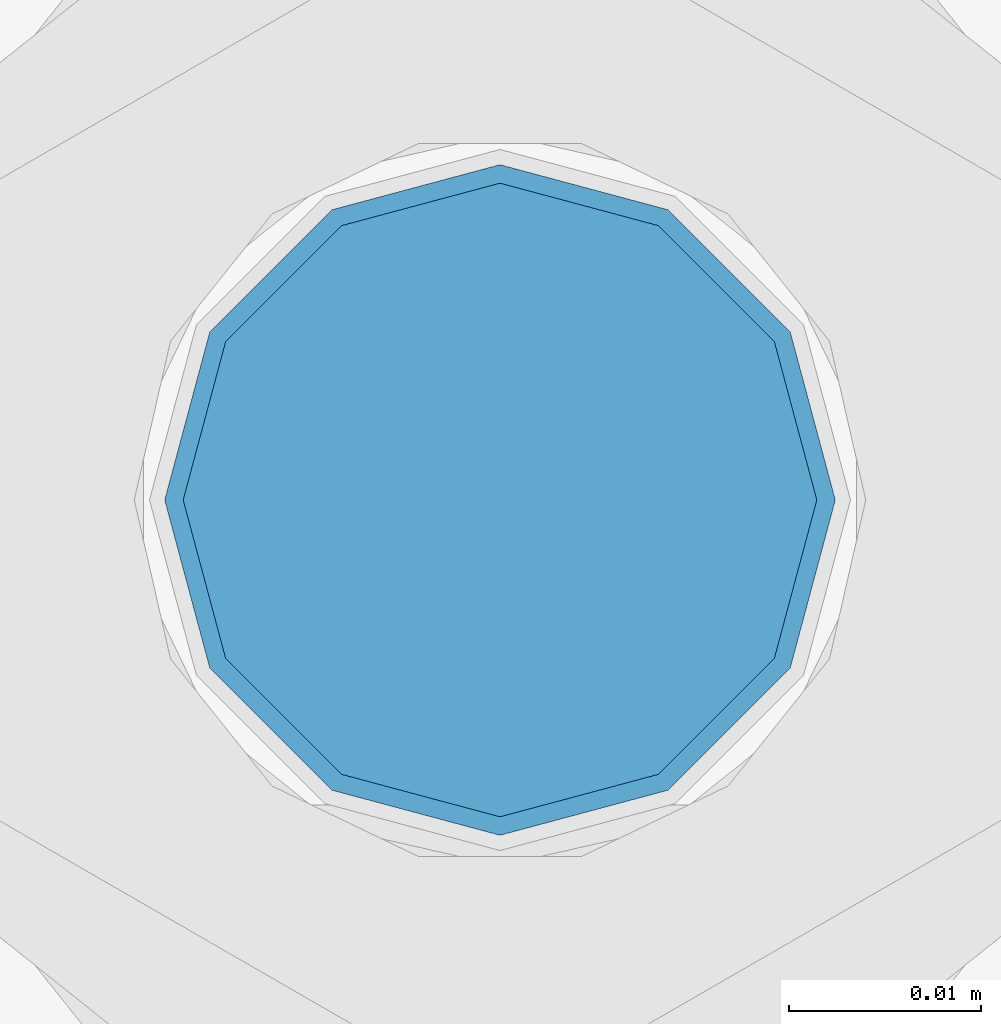
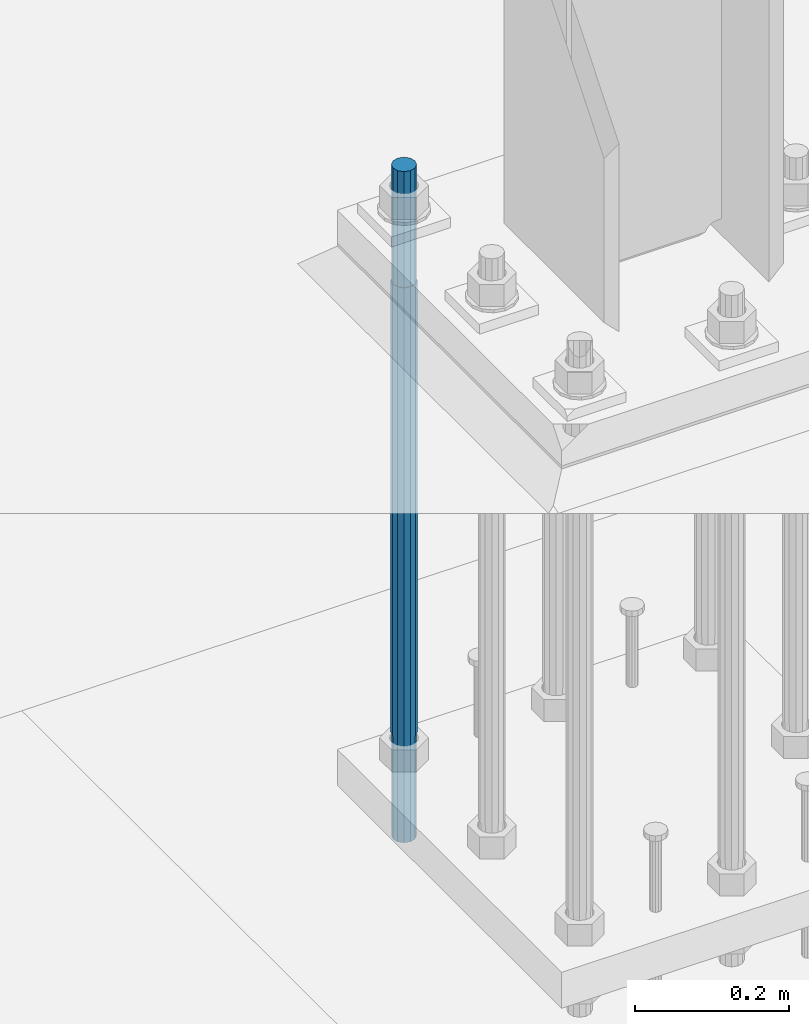
# One storey, part 567 of 1876: 1 column, 1 element without a shape of its own.
"""IFC2X3 building model written with IfcOpenShell, lengths in millimetres."""

import ifcopenshell
import ifcopenshell.guid

model = None  # the IFC model being written
_history = None  # IfcOwnerHistory: only IFC2X3 demands one
_inside = {}  # id of a spatial element -> (the spatial element, [elements in it])
_under = {}  # id of a project, library or spatial element -> (it, [spatial elements below it])
_declared = {}  # id of a project -> (the project, [libraries it declares])
_typed = {}  # id of a type object -> (the type object, [elements of that type])
_made_of = {}  # id of a material, layer set ... -> (it, [elements and type objects made of it])


def new_model(schema):
    """Start an empty IFC model of exactly this schema.

    Asked for "IFC4X3", IfcOpenShell would pick the latest addendum, in which some entities
    have other attributes; the version numbers below select the first issue.
    IFC2X3 requires an IfcOwnerHistory on every rooted entity: one is made here for all.
    """
    global model, _history
    if schema == "IFC4X3":
        model = ifcopenshell.file(schema_version=(4, 3, 0, 0))
    else:
        model = ifcopenshell.file(schema=schema)
    _inside.clear()
    _under.clear()
    _declared.clear()
    _typed.clear()
    _made_of.clear()
    _history = None
    if model.schema == "IFC2X3":
        org = make("IfcOrganization", Name="unknown")
        user = make(
            "IfcPersonAndOrganization",
            ThePerson=make("IfcPerson", FamilyName="unknown"),
            TheOrganization=org,
        )
        app = make(
            "IfcApplication",
            ApplicationDeveloper=org,
            Version="unknown",
            ApplicationFullName="unknown",
            ApplicationIdentifier="unknown",
        )
        _history = make(
            "IfcOwnerHistory",
            OwningUser=user,
            OwningApplication=app,
            ChangeAction="ADDED",
            CreationDate=0,
        )
    return model


def make(cls, **values):
    """One entity of the class cls with the attributes given. An attribute that is None is left unset."""
    return model.create_entity(
        cls, **{name: value for name, value in values.items() if value is not None}
    )


def rooted(cls, **values):
    """An entity with a GlobalId (a new one), such as an element, a storey or a relation."""
    return make(cls, GlobalId=ifcopenshell.guid.new(), OwnerHistory=_history, **values)


def si_unit(unit_type, name, prefix=None):
    """IfcSIUnit, for example si_unit("LENGTHUNIT", "METRE", prefix="MILLI")."""
    return make("IfcSIUnit", UnitType=unit_type, Prefix=prefix, Name=name)


def assignment(units):
    """IfcUnitAssignment: the units of a project."""
    return None if units is None else make("IfcUnitAssignment", Units=units)


def point(xyz):
    """IfcCartesianPoint."""
    return None if xyz is None else make("IfcCartesianPoint", Coordinates=xyz)


def direction(xyz):
    """IfcDirection."""
    return None if xyz is None else make("IfcDirection", DirectionRatios=xyz)


def frame(location, z_axis=None, x_axis=None):
    """IfcAxis2Placement3D, a coordinate frame: its origin and axes. An axis left out is left unset."""
    return make(
        "IfcAxis2Placement3D",
        Location=point(location),
        Axis=direction(z_axis),
        RefDirection=direction(x_axis),
    )


def origin_with_axes():
    """The frame at (0, 0, 0) with the z axis (0, 0, 1) and the x axis (1, 0, 0) written out."""
    return frame((0.0, 0.0, 0.0), z_axis=(0.0, 0.0, 1.0), x_axis=(1.0, 0.0, 0.0))


def place(relative_to, where):
    """IfcLocalPlacement: puts the frame where relative to a parent placement (None: the world)."""
    return make(
        "IfcLocalPlacement", PlacementRelTo=relative_to, RelativePlacement=where
    )


def context(
    kind, dimensions, precision=None, world=None, true_north=None, identifier=None
):
    """IfcGeometricRepresentationContext, for example the 3D "Model" context."""
    return make(
        "IfcGeometricRepresentationContext",
        ContextIdentifier=identifier,
        ContextType=kind,
        CoordinateSpaceDimension=dimensions,
        Precision=precision,
        WorldCoordinateSystem=world,
        TrueNorth=true_north,
    )


def subcontext(parent, identifier, kind, view, scale=None):
    """IfcGeometricRepresentationSubContext, for example "Body" below "Model"."""
    return make(
        "IfcGeometricRepresentationSubContext",
        ContextIdentifier=identifier,
        ContextType=kind,
        ParentContext=parent,
        TargetScale=scale,
        TargetView=view,
    )


def project(units=None, contexts=None):
    """IfcProject with its units and contexts."""
    return rooted(
        "IfcProject",
        Name="project",
        RepresentationContexts=contexts,
        UnitsInContext=assignment(units),
    )


def spatial(cls, under=None, at=None, **own):
    """A site, building, storey or space (cls), placed at a placement, below another one or the project."""
    s = rooted(cls, ObjectPlacement=at, **own)
    if under is not None:
        _under.setdefault(under.id(), (under, []))[1].append(s)
    return s


def faces_of(points, faces, orient=None, outer=None):
    """IfcFace entities. A face is a list of loops; a loop is a list of indices into points, from 0.

    orient and outer hold one flag for each loop. By default every Orientation is true, the
    first loop of a face is its IfcFaceOuterBound and the others are IfcFaceBound.
    """
    made = []
    for i, loops in enumerate(faces):
        bounds = []
        for j, loop in enumerate(loops):
            is_outer = j == 0 if outer is None else outer[i][j]
            bounds.append(
                make(
                    "IfcFaceOuterBound" if is_outer else "IfcFaceBound",
                    Bound=make("IfcPolyLoop", Polygon=[points[k] for k in loop]),
                    Orientation=True if orient is None else orient[i][j],
                )
            )
        made.append(make("IfcFace", Bounds=bounds))
    return made


def faceted_brep(points, faces, orient=None, outer=None, voids=None):
    """IfcFacetedBrep: a solid bounded by flat faces; with voids (closed shells), ...WithVoids."""
    shared = [point(p) for p in points]
    hull = make("IfcClosedShell", CfsFaces=faces_of(shared, faces, orient, outer))
    if voids is None:
        return make("IfcFacetedBrep", Outer=hull)
    return make(
        "IfcFacetedBrepWithVoids",
        Outer=hull,
        Voids=[
            make(cls, CfsFaces=faces_of(shared, fs, o, b)) for cls, fs, o, b in voids
        ],
    )


def shape(context_of_items, identifier, shape_type, items):
    """IfcShapeRepresentation: the items that make up one representation, for example the "Body"."""
    return make(
        "IfcShapeRepresentation",
        ContextOfItems=context_of_items,
        RepresentationIdentifier=identifier,
        RepresentationType=shape_type,
        Items=items,
    )


def material(Name=None, Category=None):
    """IfcMaterial."""
    return make("IfcMaterial", Name=Name, Category=Category)


def made_of(thing, what):
    """Note that an element or type object is made of a material, layer set ...; save() writes the relation."""
    if what is not None:
        _made_of.setdefault(what.id(), (what, []))[1].append(thing)
    return thing


def type_object(cls, material=None, **own):
    """A type object (cls), such as IfcWallType, which elements share."""
    return made_of(rooted(cls, **own), material)


def element(
    cls,
    number,
    at=None,
    inside=None,
    cuts=None,
    type_object=None,
    material=None,
    context=None,
    identifier="Body",
    shape_type=None,
    held_by="IfcProductDefinitionShape",
    body=None,
    shapes=None,
    **own,
):
    """One element of the class cls, such as IfcWall. Its Tag is "e" and its number.

    at: its placement. inside: the storey or other place that contains it. cuts: it is an
    opening in that element (IfcRelVoidsElement). A single representation is given by context,
    identifier, shape_type and body (its items); several are given by shapes. held_by: the class
    of the entity that holds the representations. save() writes the other relations.
    """
    e = rooted(cls, Tag="e%d" % number, ObjectPlacement=at, **own)
    if body is not None:
        shapes = [shape(context, identifier, shape_type, body)]
    if shapes is not None:
        e.Representation = make(held_by, Representations=shapes)
    if inside is not None:
        _inside.setdefault(inside.id(), (inside, []))[1].append(e)
    if cuts is not None:
        rooted(
            "IfcRelVoidsElement", RelatingBuildingElement=cuts, RelatedOpeningElement=e
        )
    if type_object is not None:
        _typed.setdefault(type_object.id(), (type_object, []))[1].append(e)
    return made_of(e, material)


def aggregate(whole, parts):
    """IfcRelAggregates: a whole, such as a stair, and the parts it consists of."""
    return rooted("IfcRelAggregates", RelatingObject=whole, RelatedObjects=parts)


def save(model, path):
    """Write the relations noted so far, then the file.

    IfcRelAggregates (storeys below a building ...), IfcRelContainedInSpatialStructure (elements
    in a storey), IfcRelDefinesByType, IfcRelAssociatesMaterial and IfcRelDeclares: one each for
    every whole, place, type object, material and project.
    """
    for whole, parts in _under.values():
        aggregate(whole, parts)
    for where, things in _inside.values():
        rooted(
            "IfcRelContainedInSpatialStructure",
            RelatedElements=things,
            RelatingStructure=where,
        )
    for kind, things in _typed.values():
        rooted("IfcRelDefinesByType", RelatedObjects=things, RelatingType=kind)
    for what, things in _made_of.values():
        rooted("IfcRelAssociatesMaterial", RelatedObjects=things, RelatingMaterial=what)
    for by, libraries in _declared.values():
        rooted("IfcRelDeclares", RelatingContext=by, RelatedDefinitions=libraries)
    model.write(path)


model = new_model("IFC2X3")

# Units and contexts
model_context = context("Model", 3, precision=1e-05, world=origin_with_axes())
body_context = subcontext(model_context, "Body", "Model", "MODEL_VIEW")
ifc_project = project(units=[si_unit("LENGTHUNIT", "METRE", prefix="MILLI"), si_unit("AREAUNIT", "SQUARE_METRE"), si_unit("VOLUMEUNIT", "CUBIC_METRE"), si_unit("MASSUNIT", "GRAM", prefix="KILO"), si_unit("TIMEUNIT", "SECOND"), si_unit("PLANEANGLEUNIT", "RADIAN"), si_unit("SOLIDANGLEUNIT", "STERADIAN"), si_unit("THERMODYNAMICTEMPERATUREUNIT", "DEGREE_CELSIUS"), si_unit("LUMINOUSINTENSITYUNIT", "LUMEN")], contexts=[model_context])

# Site, building, storey
site_placement = place(None, origin_with_axes())
site = spatial("IfcSite", under=ifc_project, at=site_placement, CompositionType="ELEMENT")
building_placement = place(site_placement, origin_with_axes())
building = spatial("IfcBuilding", under=site, at=building_placement, Name="Undefined", CompositionType="ELEMENT")
storey_placement = place(building_placement, origin_with_axes())
storey = spatial("IfcBuildingStorey", under=building, at=storey_placement, Name="Undefined", CompositionType="ELEMENT", Elevation=0.0)

# Assembly, column
assembly_placement = place(storey_placement, origin_with_axes())
assembly = element("IfcElementAssembly", 1, at=assembly_placement, inside=storey, Name="TEMPLATE", AssemblyPlace="NOTDEFINED", PredefinedType="RIGID_FRAME")
ifc_material = material(Name="STEEL/F1554-GR.105")
column_type = type_object("IfcColumnType", PredefinedType="NOTDEFINED")
column_placement = place(assembly_placement, frame((1498.6, -6883.4, 0.0), z_axis=(-1.0, 0.0, 0.0), x_axis=(0.0, 0.0, -1.0)))
column = element("IfcColumn", 2, at=column_placement, type_object=column_type, material=ifc_material, Name="ANCHOR_BOLTS", context=body_context, shape_type="Brep", body=[
    faceted_brep([(-184.15, -14.2894191624437, 8.25), (-184.15, -8.25, 14.2894191624432), (-184.15, 0.0, 16.5), (-184.15, 8.25, 14.2894191624432), (-184.15, 14.2894191624437, 8.25), (-184.15, 16.5, 0.0), (-184.15, 14.2894191624437, -8.25), (-184.15, 8.25, -14.2894191624432), (-184.15, 0.0, -16.5), (-184.15, -8.25, -14.2894191624432), (-184.15, -14.2894191624437, -8.25), (-184.15, -16.5, 0.0), (0.0, 16.5, 0.0), (0.0, 14.2894191624437, -8.25), (0.0, 8.25, -14.2894191624432), (0.0, 0.0, -16.5), (0.0, -8.25, -14.2894191624432), (0.0, -14.2894191624437, -8.25), (0.0, -16.5, 0.0), (0.0, -14.2894191624437, 8.25), (0.0, -8.25, 14.2894191624432), (0.0, 0.0, 16.5), (0.0, 8.25, 14.2894191624432), (0.0, 14.2894191624437, 8.25), (0.0, -15.1229686135858, 8.73125000000073), (0.0, -8.73124999999999, 15.1229686135848), (0.0, 0.0, 17.4625000000015), (0.0, 8.73124999999999, 15.1229686135848), (0.0, 15.1229686135858, 8.73125000000073), (0.0, 17.4625, 0.0), (0.0, 15.1229686135858, -8.73125000000073), (0.0, 8.73124999999999, -15.1229686135848), (0.0, 0.0, -17.4625000000015), (0.0, -8.73124999999999, -15.1229686135848), (0.0, -15.1229686135857, -8.73125000000073), (0.0, -17.4625, 0.0), (717.55, -17.4624999999996, 0.0), (717.55, -15.1229686135857, 8.73125000000005), (717.55, -8.73124999999982, 15.1229686135857), (717.55, 0.0, 17.4625000000001), (717.55, 8.73124999999982, 15.1229686135857), (717.55, 15.1229686135857, 8.73125000000005), (717.55, 17.4624999999996, 0.0), (717.55, 15.1229686135857, -8.73125000000005), (717.55, 8.73124999999982, -15.1229686135857), (717.55, 0.0, -17.4625000000001), (717.55, -8.73124999999982, -15.1229686135857), (717.55, -15.1229686135857, -8.73125000000005), (717.55, -8.25, 14.2894191624432), (717.55, 0.0, 16.5), (717.55, 8.25, 14.2894191624432), (717.55, 14.2894191624437, 8.25), (717.55, 16.5, 0.0), (717.55, 14.2894191624437, -8.25), (717.55, 8.25, -14.2894191624432), (717.55, 0.0, -16.5), (717.55, -8.25, -14.2894191624432), (717.55, -14.2894191624437, -8.25), (717.55, -16.5, 0.0), (717.55, -14.2894191624437, 8.25), (882.65, -8.25, -14.2894191624432), (882.65, 0.0, -16.5), (882.65, 8.25, -14.2894191624432), (882.65, 14.2894191624437, -8.25), (882.65, 16.5, 0.0), (882.65, 14.2894191624437, 8.25), (882.65, 8.25, 14.2894191624432), (882.65, 0.0, 16.5), (882.65, -8.25, 14.2894191624432), (882.65, -14.2894191624437, 8.25), (882.65, -16.5, 0.0), (882.65, -14.2894191624437, -8.25)], [[[0, 1, 2, 3, 4, 5, 6, 7, 8, 9, 10, 11]], [[6, 5, 12, 13]], [[7, 6, 13, 14]], [[8, 7, 14, 15]], [[9, 8, 15, 16]], [[10, 9, 16, 17]], [[11, 10, 17, 18]], [[0, 11, 18, 19]], [[1, 0, 19, 20]], [[2, 1, 20, 21]], [[3, 2, 21, 22]], [[4, 3, 22, 23]], [[5, 4, 23, 12]], [[24, 25, 26, 27, 28, 29, 30, 31, 32, 33, 34, 35], [22, 21, 20, 19, 18, 17, 16, 15, 14, 13, 12, 23]], [[24, 35, 36, 37]], [[25, 24, 37, 38]], [[26, 25, 38, 39]], [[27, 26, 39, 40]], [[28, 27, 40, 41]], [[29, 28, 41, 42]], [[30, 29, 42, 43]], [[31, 30, 43, 44]], [[32, 31, 44, 45]], [[33, 32, 45, 46]], [[34, 33, 46, 47]], [[35, 34, 47, 36]], [[46, 45, 44, 43, 42, 41, 40, 39, 38, 37, 36, 47], [48, 49, 50, 51, 52, 53, 54, 55, 56, 57, 58, 59]], [[60, 61, 62, 63, 64, 65, 66, 67, 68, 69, 70, 71]], [[68, 67, 49, 48]], [[69, 68, 48, 59]], [[70, 69, 59, 58]], [[71, 70, 58, 57]], [[60, 71, 57, 56]], [[61, 60, 56, 55]], [[62, 61, 55, 54]], [[63, 62, 54, 53]], [[64, 63, 53, 52]], [[65, 64, 52, 51]], [[66, 65, 51, 50]], [[67, 66, 50, 49]]]),
])
aggregate(assembly, [column])

save(model, "model.ifc")
